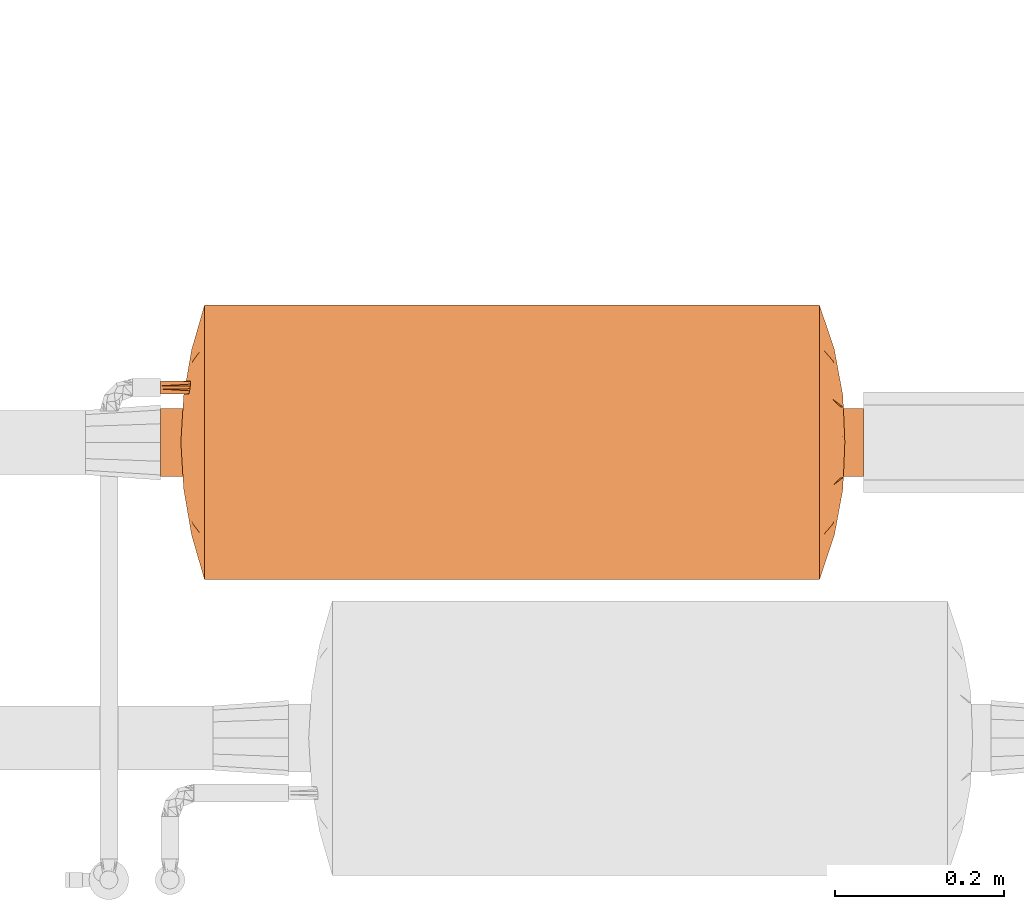
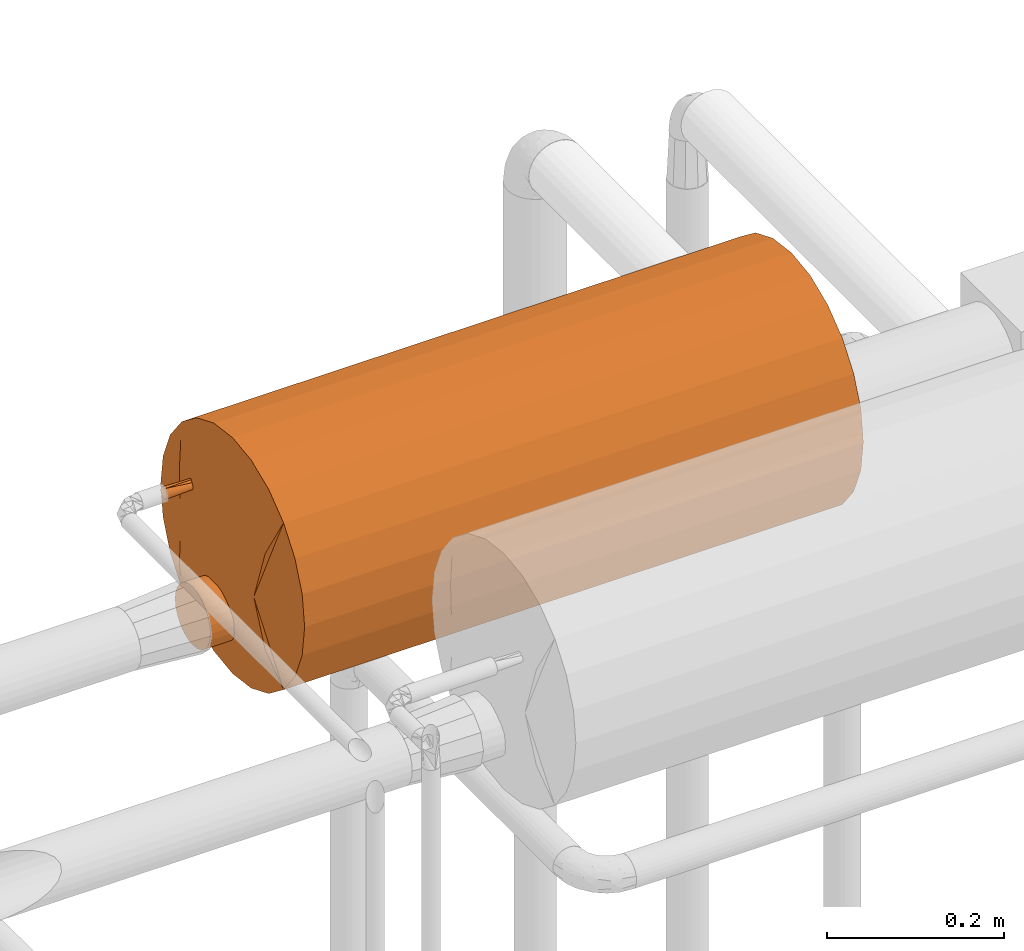
# One storey, part 827 of 827: 1 proxy.
"""IFC2X3 building model written with IfcOpenShell, lengths in millimetres."""

from ifc_helpers import new_model, entity, si_unit, converted_unit, derived_unit, direction, frame, origin, place, context, subcontext, project, spatial, faceted_brep, source, transform, mapped, material, material_list, type_object, type_shapes, element, save


model = new_model("IFC2X3")

# Units and contexts
model_context = context("Model", 3, precision=0.01, world=origin(), true_north=direction((6.12303176911189e-17, 1.0)))
body_context = subcontext(model_context, "Body", "Model", "MODEL_VIEW")
ifc_project = project(units=[si_unit("LENGTHUNIT", "METRE", prefix="MILLI"), si_unit("AREAUNIT", "SQUARE_METRE"), si_unit("VOLUMEUNIT", "CUBIC_METRE"), converted_unit("PLANEANGLEUNIT", "DEGREE", entity("IfcRatioMeasure", 0.0174532925199433), si_unit("PLANEANGLEUNIT", "RADIAN"), dimensions=[0, 0, 0, 0, 0, 0, 0]), si_unit("MASSUNIT", "GRAM", prefix="KILO"), derived_unit("MASSDENSITYUNIT", [(si_unit("MASSUNIT", "GRAM", prefix="KILO"), 1), (si_unit("LENGTHUNIT", "METRE"), -3)]), derived_unit("MOMENTOFINERTIAUNIT", [(si_unit("LENGTHUNIT", "METRE"), 4)]), si_unit("TIMEUNIT", "SECOND"), si_unit("FREQUENCYUNIT", "HERTZ"), si_unit("THERMODYNAMICTEMPERATUREUNIT", "DEGREE_CELSIUS"), derived_unit("THERMALTRANSMITTANCEUNIT", [(si_unit("MASSUNIT", "GRAM", prefix="KILO"), 1), (si_unit("THERMODYNAMICTEMPERATUREUNIT", "KELVIN"), -1), (si_unit("TIMEUNIT", "SECOND"), -3)]), derived_unit("VOLUMETRICFLOWRATEUNIT", [(si_unit("LENGTHUNIT", "METRE"), 3), (si_unit("TIMEUNIT", "SECOND"), -1)]), derived_unit("MASSFLOWRATEUNIT", [(si_unit("MASSUNIT", "GRAM", prefix="KILO"), 1), (si_unit("TIMEUNIT", "SECOND"), -1)]), derived_unit("ROTATIONALFREQUENCYUNIT", [(si_unit("TIMEUNIT", "SECOND"), -1)]), si_unit("ELECTRICCURRENTUNIT", "AMPERE"), si_unit("ELECTRICVOLTAGEUNIT", "VOLT"), si_unit("POWERUNIT", "WATT"), si_unit("FORCEUNIT", "NEWTON", prefix="KILO"), si_unit("ILLUMINANCEUNIT", "LUX"), si_unit("LUMINOUSFLUXUNIT", "LUMEN"), si_unit("LUMINOUSINTENSITYUNIT", "CANDELA"), derived_unit("USERDEFINED", [(si_unit("MASSUNIT", "GRAM", prefix="KILO"), -1), (si_unit("LENGTHUNIT", "METRE"), -2), (si_unit("TIMEUNIT", "SECOND"), 3), (si_unit("LUMINOUSFLUXUNIT", "LUMEN"), 1)]), derived_unit("LINEARVELOCITYUNIT", [(si_unit("LENGTHUNIT", "METRE"), 1), (si_unit("TIMEUNIT", "SECOND"), -1)]), si_unit("PRESSUREUNIT", "PASCAL"), derived_unit("USERDEFINED", [(si_unit("LENGTHUNIT", "METRE"), -2), (si_unit("MASSUNIT", "GRAM", prefix="KILO"), 1), (si_unit("TIMEUNIT", "SECOND"), -2)]), derived_unit("LINEARFORCEUNIT", [(si_unit("MASSUNIT", "GRAM", prefix="KILO"), 1), (si_unit("LENGTHUNIT", "METRE"), 1), (si_unit("TIMEUNIT", "SECOND"), -2), (si_unit("LENGTHUNIT", "METRE"), -1)]), derived_unit("PLANARFORCEUNIT", [(si_unit("MASSUNIT", "GRAM", prefix="KILO"), 1), (si_unit("LENGTHUNIT", "METRE"), 1), (si_unit("TIMEUNIT", "SECOND"), -2), (si_unit("LENGTHUNIT", "METRE"), -2)])], contexts=[model_context])

# Site, building, storey
site_placement = place(None, origin())
site = spatial("IfcSite", under=ifc_project, at=site_placement, CompositionType="ELEMENT")
building_placement = place(site_placement, origin())
building = spatial("IfcBuilding", under=site, at=building_placement, CompositionType="ELEMENT")
storey_placement = place(building_placement, frame((0.0, 0.0, 28200.0)))
storey = spatial("IfcBuildingStorey", under=building, at=storey_placement, Name="08", CompositionType="ELEMENT", Elevation=28200.0)

# Proxy
ifc_material_1 = material()
ifc_material_2 = material()
ifc_material_3 = material()
ifc_material_list = material_list([ifc_material_1, ifc_material_2, ifc_material_3])
building_element_proxy_type = type_object("IfcBuildingElementProxyType", Name=":Dy80", PredefinedType="NOTDEFINED", material=ifc_material_1)
shared_shape = source(origin(), body_context, "Body", "Brep", [
    faceted_brep([(66.94, 416.0, 57.76), (65.0, 416.0, 57.5), (63.06, 416.0, 57.76), (61.25, 416.0, 58.5), (59.7, 416.0, 59.7), (58.5, 416.0, 61.25), (57.76, 416.0, 63.06), (57.5, 416.0, 65.0), (57.76, 416.0, 66.94), (58.5, 416.0, 68.75), (59.7, 416.0, 70.3), (61.25, 416.0, 71.5), (63.06, 416.0, 72.24), (65.0, 416.0, 72.5), (66.94, 416.0, 72.24), (68.75, 416.0, 71.5), (70.3, 416.0, 70.3), (71.5, 416.0, 68.75), (72.24, 416.0, 66.94), (72.5, 416.0, 65.0), (72.24, 416.0, 63.06), (71.5, 416.0, 61.25), (70.3, 416.0, 59.7), (68.75, 416.0, 58.5), (68.75, 0.0, 71.5), (66.94, 0.0, 72.24), (65.0, 0.0, 72.5), (63.06, 0.0, 72.24), (61.25, 0.0, 71.5), (59.7, 0.0, 70.3), (58.5, 0.0, 68.75), (57.76, 0.0, 66.94), (57.5, 0.0, 65.0), (57.76, 0.0, 63.06), (58.5, 0.0, 61.25), (59.7, 0.0, 59.7), (61.25, 0.0, 58.5), (63.06, 0.0, 57.76), (65.0, 0.0, 57.5), (66.94, 0.0, 57.76), (68.75, 0.0, 58.5), (70.3, 0.0, 59.7), (71.5, 0.0, 61.25), (72.24, 0.0, 63.06), (72.5, 0.0, 65.0), (72.24, 0.0, 66.94), (71.5, 0.0, 68.75), (70.3, 0.0, 70.3), (72.5, 320.38, 65.0), (65.49, 181.32, 57.52), (72.5, 224.75, 65.0), (72.5, 208.0, 65.0), (72.5, 95.62, 65.0), (65.0, 272.56, 57.5), (57.5, 208.0, 65.0), (57.5, 224.75, 65.0), (57.5, 320.38, 65.0), (65.0, 84.55, 57.5), (57.5, 95.62, 65.0), (65.0, 84.55, 72.5), (65.0, 272.56, 72.5), (64.51, 181.32, 72.48)], [[[0, 1, 2, 3, 4, 5, 6, 7, 8, 9, 10, 11, 12, 13, 14, 15, 16, 17, 18, 19, 20, 21, 22, 23]], [[24, 25, 26, 27, 28, 29, 30, 31, 32, 33, 34, 35, 36, 37, 38, 39, 40, 41, 42, 43, 44, 45, 46, 47]], [[23, 22, 48]], [[49, 50, 51, 52]], [[53, 54, 55, 56]], [[37, 36, 57]], [[48, 22, 21]], [[37, 57, 38]], [[1, 53, 2]], [[56, 5, 4]], [[35, 34, 58]], [[57, 40, 39]], [[49, 57, 58]], [[33, 32, 58]], [[56, 7, 6]], [[54, 49, 58]], [[56, 6, 5]], [[53, 49, 54]], [[20, 19, 48]], [[52, 44, 43]], [[35, 57, 36]], [[40, 57, 41]], [[48, 50, 53]], [[33, 58, 34]], [[52, 42, 41]], [[52, 57, 49]], [[43, 42, 52]], [[57, 35, 58]], [[49, 53, 50]], [[20, 48, 21]], [[38, 57, 39]], [[0, 53, 1]], [[4, 3, 56]], [[0, 48, 53]], [[48, 0, 23]], [[2, 53, 56]], [[56, 3, 2]], [[57, 52, 41]], [[56, 11, 10]], [[25, 24, 59]], [[56, 10, 9]], [[25, 59, 26]], [[13, 60, 14]], [[47, 46, 52]], [[59, 28, 27]], [[61, 55, 54, 58]], [[56, 55, 60]], [[61, 59, 52]], [[45, 44, 52]], [[48, 19, 18]], [[17, 16, 48]], [[18, 17, 48]], [[8, 7, 56]], [[58, 32, 31]], [[61, 51, 60]], [[51, 61, 52]], [[29, 28, 59]], [[47, 59, 24]], [[58, 30, 29]], [[60, 51, 50, 48]], [[58, 59, 61]], [[31, 30, 58]], [[47, 52, 59]], [[55, 61, 60]], [[8, 56, 9]], [[12, 60, 13]], [[26, 59, 27]], [[16, 15, 48]], [[12, 56, 60]], [[56, 12, 11]], [[60, 48, 14]], [[48, 15, 14]], [[45, 52, 46]], [[59, 58, 29]]]),
    faceted_brep([(28.17, 416.0, -93.28), (19.88, 416.0, -99.64), (10.24, 416.0, -103.64), (-0.12, 416.0, -105.0), (-10.47, 416.0, -103.64), (-20.12, 416.0, -99.64), (-28.4, 416.0, -93.28), (-34.76, 416.0, -85.0), (-38.75, 416.0, -75.35), (-40.12, 416.0, -65.0), (-38.75, 416.0, -54.65), (-34.76, 416.0, -45.0), (-28.4, 416.0, -36.72), (-20.12, 416.0, -30.36), (-10.47, 416.0, -26.36), (-0.12, 416.0, -25.0), (10.24, 416.0, -26.36), (19.88, 416.0, -30.36), (28.17, 416.0, -36.72), (34.52, 416.0, -45.0), (38.52, 416.0, -54.65), (39.88, 416.0, -65.0), (38.52, 416.0, -75.35), (34.52, 416.0, -85.0), (19.88, -416.0, -30.36), (10.24, -416.0, -26.36), (-0.12, -416.0, -25.0), (-10.47, -416.0, -26.36), (-20.12, -416.0, -30.36), (-28.4, -416.0, -36.72), (-34.76, -416.0, -45.0), (-38.75, -416.0, -54.65), (-40.12, -416.0, -65.0), (-38.75, -416.0, -75.35), (-34.76, -416.0, -85.0), (-28.4, -416.0, -93.28), (-20.12, -416.0, -99.64), (-10.47, -416.0, -103.64), (-0.12, -416.0, -105.0), (10.24, -416.0, -103.64), (19.88, -416.0, -99.64), (28.17, -416.0, -93.28), (34.52, -416.0, -85.0), (38.52, -416.0, -75.35), (39.88, -416.0, -65.0), (38.52, -416.0, -54.65), (34.52, -416.0, -45.0), (28.17, -416.0, -36.72), (-37.07, 0.0, -80.31), (-5.34, 184.0, -104.66), (-15.42, 0.0, -101.96), (-31.85, -103.67, -89.35), (-31.85, 184.0, -89.35), (-24.47, 103.67, -96.73), (-24.47, -184.0, -96.73), (31.62, -184.0, -89.35), (24.23, -103.67, -96.73), (31.62, 103.67, -89.35), (24.23, 184.0, -96.73), (-5.34, -103.67, -104.66), (-39.35, -138.45, -72.8), (-39.41, 146.88, -72.49), (-40.12, 0.0, -65.0), (5.1, 103.67, -104.66), (5.1, -184.0, -104.66), (15.19, 0.0, -101.96), (36.84, 0.0, -80.31), (39.17, -146.88, -72.49), (39.88, 0.0, -65.0), (39.11, 138.45, -72.8), (39.88, 25.67, -65.0), (24.23, 184.0, -33.27), (36.84, -184.0, -49.69), (31.62, 0.0, -40.65), (24.23, -103.67, -33.27), (15.19, 0.0, -28.04), (-31.85, -184.0, -40.65), (-24.47, -103.67, -33.27), (-31.85, 103.67, -40.65), (-24.47, 184.0, -33.27), (5.1, -103.67, -25.34), (39.15, 107.63, -57.39), (39.29, -153.03, -58.11), (36.84, 103.67, -49.69), (5.1, 184.0, -25.34), (-15.42, 0.0, -28.04), (-5.34, -184.0, -25.34), (-5.34, 103.67, -25.34), (-37.07, 0.0, -49.69), (-39.41, -146.88, -57.51), (-39.35, 138.45, -57.2)], [[[0, 1, 2, 3, 4, 5, 6, 7, 8, 9, 10, 11, 12, 13, 14, 15, 16, 17, 18, 19, 20, 21, 22, 23]], [[24, 25, 26, 27, 28, 29, 30, 31, 32, 33, 34, 35, 36, 37, 38, 39, 40, 41, 42, 43, 44, 45, 46, 47]], [[34, 33, 48]], [[4, 49, 50]], [[51, 52, 53, 54]], [[48, 51, 34]], [[37, 36, 50]], [[55, 41, 56]], [[0, 57, 58]], [[53, 50, 54]], [[7, 52, 48]], [[37, 50, 59]], [[60, 48, 33]], [[61, 62, 9]], [[32, 60, 33]], [[51, 35, 34]], [[6, 5, 53]], [[48, 8, 7]], [[3, 2, 63]], [[52, 51, 48]], [[50, 53, 5]], [[56, 41, 40]], [[50, 5, 4]], [[59, 38, 37]], [[49, 59, 50]], [[59, 49, 63, 64]], [[40, 39, 65]], [[64, 38, 59]], [[3, 63, 49]], [[65, 56, 40]], [[43, 42, 66]], [[55, 42, 41]], [[54, 35, 51]], [[57, 66, 55]], [[0, 58, 1]], [[67, 68, 44]], [[63, 2, 65]], [[65, 2, 1]], [[54, 36, 35]], [[0, 23, 57]], [[61, 60, 62]], [[58, 56, 65]], [[3, 49, 4]], [[57, 23, 66]], [[22, 66, 23]], [[64, 39, 38]], [[22, 69, 66]], [[6, 52, 7]], [[6, 53, 52]], [[64, 63, 65]], [[67, 69, 68]], [[22, 21, 69]], [[36, 54, 50]], [[1, 58, 65]], [[56, 58, 57, 55]], [[39, 64, 65]], [[42, 55, 66]], [[8, 48, 61]], [[62, 60, 32]], [[60, 61, 48]], [[8, 61, 9]], [[43, 66, 67]], [[69, 21, 70, 68]], [[69, 67, 66]], [[43, 67, 44]], [[71, 18, 17]], [[46, 72, 73]], [[74, 71, 75]], [[46, 73, 47]], [[25, 24, 75]], [[76, 29, 77]], [[12, 78, 79]], [[74, 47, 73]], [[18, 71, 73]], [[25, 75, 80]], [[81, 70, 21]], [[82, 72, 45]], [[77, 29, 28]], [[74, 24, 47]], [[20, 19, 83]], [[83, 19, 73]], [[72, 83, 73]], [[73, 19, 18]], [[74, 73, 71]], [[80, 26, 25]], [[75, 17, 16]], [[45, 44, 82]], [[84, 80, 75]], [[82, 81, 83]], [[28, 27, 85]], [[86, 26, 80]], [[15, 87, 84]], [[85, 77, 28]], [[31, 30, 88]], [[76, 30, 29]], [[15, 84, 16]], [[78, 88, 76]], [[12, 79, 13]], [[89, 62, 32]], [[87, 14, 85]], [[85, 14, 13]], [[12, 11, 78]], [[10, 9, 90]], [[71, 17, 75]], [[79, 77, 85]], [[45, 72, 46]], [[78, 11, 88]], [[10, 88, 11]], [[70, 81, 82]], [[10, 90, 88]], [[74, 75, 24]], [[86, 27, 26]], [[86, 87, 85]], [[89, 90, 62]], [[15, 14, 87]], [[72, 82, 83]], [[82, 44, 68, 70]], [[81, 20, 83]], [[20, 81, 21]], [[16, 84, 75]], [[80, 84, 87, 86]], [[13, 79, 85]], [[77, 79, 78]], [[27, 86, 85]], [[30, 76, 88]], [[78, 76, 77]], [[31, 88, 89]], [[62, 90, 9]], [[90, 89, 88]], [[31, 89, 32]]]),
    faceted_brep([(-159.69, 364.0, -21.32), (-161.1, 364.0, -10.66), (-162.5, 364.0, 0.0), (-155.82, 365.93, 0.0), (-149.15, 367.86, 0.0), (-135.8, 371.72, 0.0), (-156.96, 364.0, -42.06), (41.32, 389.51, 0.0), (67.08, 379.71, -84.46), (47.38, 383.12, -78.27), (-144.79, 364.0, -71.45), (-109.48, 379.34, 0.0), (-140.73, 364.0, -81.25), (85.05, 378.12, -76.87), (98.08, 364.0, -127.82), (81.25, 364.0, -140.73), (55.09, 388.69, 0.0), (68.69, 386.35, 0.0), (-95.89, 381.68, 0.0), (-82.29, 384.01, 0.0), (-114.9, 364.0, -114.9), (149.15, 367.86, 0.0), (155.82, 365.93, 0.0), (162.5, 364.0, 0.0), (161.1, 364.0, -10.66), (159.69, 364.0, -21.32), (156.96, 364.0, -42.06), (135.8, 371.72, 0.0), (-127.82, 364.0, -98.08), (-13.77, 391.14, 0.0), (0.0, 391.96, 0.0), (0.64, 388.56, -56.2), (95.89, 381.68, 0.0), (114.9, 364.0, -114.9), (82.29, 384.01, 0.0), (0.35, 379.22, -109.99), (-15.85, 384.77, -80.88), (-67.08, 379.71, -84.46), (-85.05, 378.12, -76.87), (-55.09, 388.69, 0.0), (-98.08, 364.0, -127.82), (-81.25, 364.0, -140.73), (-122.64, 375.53, 0.0), (-116.06, 377.43, 0.0), (96.75, 377.52, -65.95), (109.48, 379.34, 0.0), (127.82, 364.0, -98.08), (27.55, 390.33, 0.0), (140.73, 364.0, -81.25), (116.06, 377.43, 0.0), (148.85, 364.0, -61.65), (-148.85, 364.0, -61.65), (122.64, 375.53, 0.0), (32.54, 386.74, -62.05), (29.41, 377.03, -115.39), (-96.75, 377.52, -65.95), (-68.69, 386.35, 0.0), (16.83, 384.52, -82.16), (61.65, 364.0, -148.85), (-61.65, 364.0, -148.85), (13.77, 391.14, 0.0), (-28.0, 377.32, -114.56), (-41.32, 389.51, 0.0), (-47.38, 383.12, -78.27), (-32.15, 386.68, -62.66), (-27.55, 390.33, 0.0), (-42.06, 364.0, -156.96), (42.06, 364.0, -156.96), (21.03, 364.0, -159.73), (0.0, 364.0, -162.5), (-21.03, 364.0, -159.73), (159.69, 364.0, 21.32), (161.1, 364.0, 10.66), (156.96, 364.0, 42.06), (-67.08, 379.71, 84.46), (-47.38, 383.12, 78.27), (144.79, 364.0, 71.45), (140.73, 364.0, 81.25), (-85.05, 378.12, 76.87), (-98.08, 364.0, 127.82), (-81.25, 364.0, 140.73), (114.9, 364.0, 114.9), (-159.69, 364.0, 21.32), (-156.96, 364.0, 42.06), (-161.1, 364.0, 10.66), (127.82, 364.0, 98.08), (-0.64, 388.56, 56.2), (-114.9, 364.0, 114.9), (-0.35, 379.22, 109.99), (15.85, 384.77, 80.88), (67.08, 379.71, 84.46), (85.05, 378.12, 76.87), (98.08, 364.0, 127.82), (81.25, 364.0, 140.73), (-96.75, 377.52, 65.95), (-127.82, 364.0, 98.08), (-140.73, 364.0, 81.25), (-148.85, 364.0, 61.65), (148.85, 364.0, 61.65), (-32.54, 386.74, 62.05), (-29.41, 377.03, 115.39), (96.75, 377.52, 65.95), (-16.83, 384.52, 82.16), (-61.65, 364.0, 148.85), (61.65, 364.0, 148.85), (28.0, 377.32, 114.56), (47.38, 383.12, 78.27), (32.15, 386.68, 62.66), (42.06, 364.0, 156.96), (-42.06, 364.0, 156.96), (-21.03, 364.0, 159.73), (0.0, 364.0, 162.5), (21.03, 364.0, 159.73), (0.0, 364.0, 0.0)], [[[0, 1, 2, 3, 4, 5, 6]], [[7, 8, 9]], [[10, 11, 12]], [[13, 14, 15]], [[13, 16, 17]], [[18, 19, 20]], [[21, 22, 23, 24, 25, 26, 27]], [[20, 28, 18]], [[29, 30, 31]], [[32, 33, 34]], [[35, 36, 31]], [[37, 38, 39]], [[40, 38, 41]], [[10, 42, 43, 11]], [[13, 44, 14]], [[32, 45, 46]], [[9, 47, 7]], [[11, 28, 12]], [[13, 8, 16]], [[48, 49, 50]], [[18, 28, 11]], [[34, 33, 44]], [[44, 13, 17]], [[48, 46, 45]], [[26, 50, 27]], [[45, 49, 48]], [[10, 51, 42]], [[5, 51, 6]], [[52, 27, 50, 49]], [[42, 51, 5]], [[53, 9, 54]], [[46, 33, 32]], [[38, 55, 56]], [[53, 54, 57]], [[8, 13, 15]], [[8, 58, 9]], [[7, 16, 8]], [[53, 47, 9]], [[59, 41, 37]], [[57, 60, 53]], [[35, 61, 36]], [[37, 62, 63]], [[61, 64, 36]], [[63, 65, 64]], [[55, 38, 40]], [[20, 55, 40]], [[41, 38, 37]], [[38, 56, 39]], [[66, 59, 63]], [[59, 37, 63]], [[65, 63, 62]], [[37, 39, 62]], [[61, 66, 63]], [[67, 9, 58]], [[8, 15, 58]], [[14, 44, 33]], [[44, 17, 34]], [[55, 19, 56]], [[19, 55, 20]], [[57, 68, 35]], [[60, 31, 30]], [[54, 68, 57]], [[60, 47, 53]], [[54, 67, 68]], [[67, 54, 9]], [[69, 35, 68]], [[57, 35, 31]], [[57, 31, 60]], [[36, 29, 31]], [[61, 35, 70]], [[65, 29, 64]], [[70, 35, 69]], [[36, 64, 29]], [[64, 61, 63]], [[61, 70, 66]], [[71, 72, 23, 22, 21, 27, 73]], [[62, 74, 75]], [[76, 45, 77]], [[78, 79, 80]], [[78, 39, 56]], [[32, 34, 81]], [[82, 83, 5, 4, 3, 2, 84]], [[81, 85, 32]], [[60, 30, 86]], [[18, 87, 19]], [[88, 89, 86]], [[90, 91, 16]], [[92, 91, 93]], [[76, 52, 49, 45]], [[78, 94, 79]], [[18, 11, 95]], [[75, 65, 62]], [[45, 85, 77]], [[78, 74, 39]], [[96, 43, 97]], [[32, 85, 45]], [[19, 87, 94]], [[94, 78, 56]], [[96, 95, 11]], [[83, 97, 5]], [[11, 43, 96]], [[76, 98, 52]], [[27, 98, 73]], [[42, 5, 97, 43]], [[52, 98, 27]], [[99, 75, 100]], [[95, 87, 18]], [[91, 101, 17]], [[99, 100, 102]], [[74, 78, 80]], [[74, 103, 75]], [[62, 39, 74]], [[99, 65, 75]], [[104, 93, 90]], [[102, 29, 99]], [[88, 105, 89]], [[90, 7, 106]], [[102, 88, 86]], [[106, 47, 107]], [[101, 91, 92]], [[81, 101, 92]], [[93, 91, 90]], [[91, 17, 16]], [[108, 104, 106]], [[104, 90, 106]], [[47, 106, 7]], [[90, 16, 7]], [[105, 108, 106]], [[109, 75, 103]], [[74, 80, 103]], [[79, 94, 87]], [[94, 56, 19]], [[101, 34, 17]], [[34, 101, 81]], [[102, 110, 88]], [[29, 86, 30]], [[100, 110, 102]], [[29, 65, 99]], [[100, 109, 110]], [[109, 100, 75]], [[105, 107, 89]], [[111, 88, 110]], [[102, 86, 29]], [[89, 60, 86]], [[105, 88, 112]], [[47, 60, 107]], [[112, 88, 111]], [[89, 107, 60]], [[107, 105, 106]], [[105, 112, 108]], [[113, 26, 25]], [[113, 25, 24]], [[113, 24, 23]], [[113, 23, 72]], [[113, 50, 26]], [[113, 48, 50]], [[113, 46, 48]], [[113, 33, 46]], [[113, 14, 33]], [[113, 15, 14]], [[113, 58, 15]], [[113, 67, 58]], [[113, 68, 67]], [[113, 69, 68]], [[113, 70, 69]], [[113, 66, 70]], [[113, 59, 66]], [[113, 41, 59]], [[113, 40, 41]], [[113, 20, 40]], [[113, 28, 20]], [[113, 12, 28]], [[113, 10, 12]], [[113, 51, 10]], [[113, 6, 51]], [[113, 0, 6]], [[113, 1, 0]], [[113, 2, 1]], [[113, 72, 71]], [[113, 71, 73]], [[113, 73, 98]], [[113, 98, 76]], [[113, 76, 77]], [[113, 77, 85]], [[113, 85, 81]], [[113, 81, 92]], [[113, 92, 93]], [[113, 93, 104]], [[113, 104, 108]], [[113, 108, 112]], [[113, 112, 111]], [[113, 111, 110]], [[113, 84, 2]], [[113, 82, 84]], [[113, 83, 82]], [[113, 97, 83]], [[113, 96, 97]], [[113, 95, 96]], [[113, 87, 95]], [[113, 79, 87]], [[113, 80, 79]], [[113, 103, 80]], [[113, 109, 103]], [[113, 110, 109]]]),
    faceted_brep([(-96.96, -379.53, -66.85), (-85.06, -380.44, -76.61), (-69.03, -389.19, 0.0), (-160.28, -364.0, -16.87), (-159.45, -364.0, -23.17), (-158.62, -364.0, -29.46), (-156.96, -364.0, -42.06), (-133.54, -373.72, 0.0), (-141.41, -371.08, 0.0), (-146.69, -369.31, 0.0), (-151.96, -367.54, 0.0), (-162.5, -364.0, 0.0), (160.28, -364.0, -16.87), (162.5, -364.0, 0.0), (151.96, -367.54, 0.0), (146.69, -369.31, 0.0), (141.41, -371.08, 0.0), (133.54, -373.72, 0.0), (156.96, -364.0, -42.06), (158.62, -364.0, -29.46), (159.45, -364.0, -23.17), (-36.26, -378.67, -115.22), (-51.54, -378.96, -108.11), (-42.06, -364.0, -156.96), (-41.55, -392.28, 0.0), (-55.4, -391.71, 0.0), (-66.57, -382.24, -84.52), (-109.93, -381.64, 0.0), (-148.85, -364.0, -61.65), (-140.73, -364.0, -81.25), (-127.82, -364.0, -98.08), (148.85, -364.0, -61.65), (-125.67, -376.36, 0.0), (-82.67, -386.68, 0.0), (-114.9, -364.0, -114.9), (140.73, -364.0, -81.25), (109.93, -381.64, 0.0), (66.57, -382.24, -84.52), (41.55, -392.28, 0.0), (51.54, -378.96, -108.11), (127.82, -364.0, -98.08), (96.3, -384.16, 0.0), (114.9, -364.0, -114.9), (125.67, -376.36, 0.0), (85.06, -380.44, -76.61), (81.25, -364.0, -140.73), (96.96, -379.53, -66.85), (69.03, -389.19, 0.0), (98.08, -364.0, -127.82), (-96.3, -384.16, 0.0), (82.67, -386.68, 0.0), (13.85, -393.43, 0.0), (0.0, -394.0, 0.0), (7.51, -388.27, -79.01), (-98.08, -364.0, -127.82), (-81.25, -364.0, -140.73), (-61.65, -364.0, -148.85), (-7.04, -391.55, -56.37), (-13.85, -393.43, 0.0), (-22.95, -385.16, -92.34), (-42.17, -388.61, -64.85), (-27.7, -392.85, 0.0), (55.4, -391.71, 0.0), (42.17, -388.61, -64.85), (36.26, -378.67, -115.22), (61.65, -364.0, -148.85), (-21.03, -364.0, -159.73), (42.06, -364.0, -156.96), (22.95, -385.16, -92.34), (21.03, -364.0, -159.73), (-4.64, -381.32, -111.09), (0.0, -364.0, -162.5), (28.55, -391.9, -45.49), (27.7, -392.85, 0.0), (96.96, -379.53, 66.85), (85.06, -380.44, 76.61), (160.28, -364.0, 16.87), (159.45, -364.0, 23.17), (158.62, -364.0, 29.46), (156.96, -364.0, 42.06), (148.85, -364.0, 61.65), (36.26, -378.67, 115.22), (51.54, -378.96, 108.11), (42.06, -364.0, 156.96), (66.57, -382.24, 84.52), (-156.96, -364.0, 42.06), (-158.62, -364.0, 29.46), (-159.45, -364.0, 23.17), (-160.28, -364.0, 16.87), (140.73, -364.0, 81.25), (127.82, -364.0, 98.08), (114.9, -364.0, 114.9), (-85.06, -380.44, 76.61), (-96.96, -379.53, 66.85), (-140.73, -364.0, 81.25), (-148.85, -364.0, 61.65), (-66.57, -382.24, 84.52), (-51.54, -378.96, 108.11), (-127.82, -364.0, 98.08), (-114.9, -364.0, 114.9), (-81.25, -364.0, 140.73), (-98.08, -364.0, 127.82), (-7.51, -388.27, 79.01), (98.08, -364.0, 127.82), (81.25, -364.0, 140.73), (61.65, -364.0, 148.85), (7.04, -391.55, 56.37), (22.95, -385.16, 92.34), (42.17, -388.61, 64.85), (-42.17, -388.61, 64.85), (-36.26, -378.67, 115.22), (-61.65, -364.0, 148.85), (21.03, -364.0, 159.73), (-42.06, -364.0, 156.96), (-22.95, -385.16, 92.34), (-21.03, -364.0, 159.73), (4.64, -381.32, 111.09), (0.0, -364.0, 162.5), (-28.55, -391.9, 45.49), (0.0, -364.0, 0.0)], [[[0, 1, 2]], [[3, 4, 5, 6, 7, 8, 9, 10, 11]], [[12, 13, 14, 15, 16, 17, 18, 19, 20]], [[21, 22, 23]], [[24, 25, 26]], [[25, 1, 26]], [[27, 28, 29]], [[29, 30, 27]], [[6, 28, 7]], [[18, 17, 31]], [[28, 27, 32, 7]], [[33, 34, 0]], [[35, 31, 36]], [[37, 38, 39]], [[40, 41, 42]], [[31, 17, 43, 36]], [[44, 37, 45]], [[44, 46, 47]], [[48, 44, 45]], [[49, 27, 30]], [[41, 50, 42]], [[51, 52, 53]], [[30, 34, 49]], [[49, 34, 33]], [[41, 40, 36]], [[36, 40, 35]], [[1, 0, 54]], [[1, 54, 55]], [[1, 25, 2]], [[56, 23, 22]], [[57, 58, 59]], [[26, 1, 55]], [[26, 56, 22]], [[46, 44, 48]], [[60, 61, 24]], [[42, 46, 48]], [[44, 62, 37]], [[44, 47, 62]], [[63, 64, 39]], [[65, 45, 37]], [[39, 65, 37]], [[26, 22, 24]], [[37, 62, 38]], [[26, 55, 56]], [[21, 59, 60]], [[59, 61, 60]], [[21, 66, 59]], [[67, 39, 64]], [[67, 65, 39]], [[38, 63, 39]], [[68, 69, 64]], [[57, 59, 70]], [[54, 0, 34]], [[0, 2, 33]], [[46, 50, 47]], [[50, 46, 42]], [[22, 21, 60]], [[22, 60, 24]], [[66, 70, 59]], [[21, 23, 66]], [[58, 61, 59]], [[69, 70, 71]], [[63, 72, 68]], [[69, 67, 64]], [[64, 63, 68]], [[73, 63, 38]], [[51, 53, 72]], [[52, 58, 57]], [[70, 69, 68]], [[57, 70, 53]], [[51, 72, 73]], [[71, 70, 66]], [[52, 57, 53]], [[53, 70, 68]], [[73, 72, 63]], [[68, 72, 53]], [[74, 75, 47]], [[76, 77, 78, 79, 17, 16, 15, 14, 13]], [[80, 36, 43, 17]], [[81, 82, 83]], [[38, 62, 84]], [[62, 75, 84]], [[8, 7, 85, 86, 87, 88, 11, 10, 9]], [[36, 80, 89]], [[89, 90, 36]], [[79, 80, 17]], [[41, 36, 90]], [[50, 91, 74]], [[92, 93, 2]], [[94, 95, 27]], [[96, 24, 97]], [[98, 49, 99]], [[92, 96, 100]], [[49, 33, 99]], [[101, 92, 100]], [[32, 27, 95, 7]], [[58, 52, 102]], [[85, 7, 95]], [[90, 91, 41]], [[41, 91, 50]], [[49, 98, 27]], [[27, 98, 94]], [[75, 74, 103]], [[75, 103, 104]], [[75, 62, 47]], [[105, 83, 82]], [[106, 51, 107]], [[84, 75, 104]], [[84, 105, 82]], [[93, 92, 101]], [[108, 73, 38]], [[99, 93, 101]], [[92, 25, 96]], [[92, 2, 25]], [[109, 110, 97]], [[111, 100, 96]], [[97, 111, 96]], [[84, 82, 38]], [[96, 25, 24]], [[84, 104, 105]], [[81, 107, 108]], [[107, 73, 108]], [[81, 112, 107]], [[113, 97, 110]], [[113, 111, 97]], [[24, 109, 97]], [[114, 115, 110]], [[106, 107, 116]], [[103, 74, 91]], [[74, 47, 50]], [[93, 33, 2]], [[33, 93, 99]], [[82, 81, 108]], [[82, 108, 38]], [[112, 116, 107]], [[81, 83, 112]], [[51, 73, 107]], [[115, 116, 117]], [[109, 118, 114]], [[115, 113, 110]], [[110, 109, 114]], [[61, 109, 24]], [[58, 102, 118]], [[52, 51, 106]], [[116, 115, 114]], [[106, 116, 102]], [[58, 118, 61]], [[117, 116, 112]], [[52, 106, 102]], [[102, 116, 114]], [[61, 118, 109]], [[114, 118, 102]], [[119, 13, 12]], [[119, 12, 20]], [[119, 20, 19]], [[119, 19, 18]], [[119, 18, 31]], [[119, 31, 35]], [[119, 35, 40]], [[119, 40, 42]], [[119, 42, 48]], [[119, 48, 45]], [[119, 45, 65]], [[119, 65, 67]], [[119, 67, 69]], [[119, 69, 71]], [[119, 71, 66]], [[119, 66, 23]], [[119, 23, 56]], [[119, 56, 55]], [[119, 55, 54]], [[119, 54, 34]], [[119, 34, 30]], [[119, 30, 29]], [[119, 29, 28]], [[119, 28, 6]], [[119, 6, 5]], [[119, 5, 4]], [[119, 4, 3]], [[119, 3, 11]], [[119, 11, 88]], [[119, 76, 13]], [[119, 77, 76]], [[119, 78, 77]], [[119, 79, 78]], [[119, 80, 79]], [[119, 89, 80]], [[119, 90, 89]], [[119, 91, 90]], [[119, 103, 91]], [[119, 104, 103]], [[119, 105, 104]], [[119, 83, 105]], [[119, 112, 83]], [[119, 117, 112]], [[119, 88, 87]], [[119, 87, 86]], [[119, 86, 85]], [[119, 85, 95]], [[119, 95, 94]], [[119, 94, 98]], [[119, 98, 99]], [[119, 99, 101]], [[119, 101, 100]], [[119, 100, 111]], [[119, 111, 113]], [[119, 113, 115]], [[119, 115, 117]]]),
    faceted_brep([(42.06, 364.0, -156.96), (0.0, 364.0, -162.5), (-42.06, 364.0, -156.96), (-81.25, 364.0, -140.73), (-114.9, 364.0, -114.9), (-140.73, 364.0, -81.25), (-156.96, 364.0, -42.06), (-162.5, 364.0, 0.0), (-156.96, 364.0, 42.06), (-140.73, 364.0, 81.25), (-114.9, 364.0, 114.9), (-81.25, 364.0, 140.73), (-42.06, 364.0, 156.96), (0.0, 364.0, 162.5), (42.06, 364.0, 156.96), (81.25, 364.0, 140.73), (114.9, 364.0, 114.9), (140.73, 364.0, 81.25), (156.96, 364.0, 42.06), (162.5, 364.0, 0.0), (156.96, 364.0, -42.06), (140.73, 364.0, -81.25), (114.9, 364.0, -114.9), (81.25, 364.0, -140.73), (42.06, -364.0, 156.96), (0.0, -364.0, 162.5), (-42.06, -364.0, 156.96), (-81.25, -364.0, 140.73), (-114.9, -364.0, 114.9), (-140.73, -364.0, 81.25), (-156.96, -364.0, 42.06), (-162.5, -364.0, 0.0), (-156.96, -364.0, -42.06), (-140.73, -364.0, -81.25), (-114.9, -364.0, -114.9), (-81.25, -364.0, -140.73), (-42.06, -364.0, -156.96), (0.0, -364.0, -162.5), (42.06, -364.0, -156.96), (81.25, -364.0, -140.73), (114.9, -364.0, -114.9), (140.73, -364.0, -81.25), (156.96, -364.0, -42.06), (162.5, -364.0, 0.0), (156.96, -364.0, 42.06), (140.73, -364.0, 81.25), (114.9, -364.0, 114.9), (81.25, -364.0, 140.73)], [[[0, 1, 2, 3, 4, 5, 6, 7, 8, 9, 10, 11, 12, 13, 14, 15, 16, 17, 18, 19, 20, 21, 22, 23]], [[24, 25, 26, 27, 28, 29, 30, 31, 32, 33, 34, 35, 36, 37, 38, 39, 40, 41, 42, 43, 44, 45, 46, 47]], [[33, 32, 6, 5]], [[33, 5, 4, 34]], [[36, 35, 3, 2]], [[4, 3, 35, 34]], [[37, 36, 2, 1]], [[31, 7, 6, 32]], [[39, 38, 0, 23]], [[39, 23, 22, 40]], [[42, 41, 21, 20]], [[22, 21, 41, 40]], [[43, 42, 20, 19]], [[1, 0, 38, 37]], [[46, 45, 17, 16]], [[24, 47, 15, 14]], [[16, 15, 47, 46]], [[24, 14, 13, 25]], [[18, 44, 43, 19]], [[18, 17, 45, 44]], [[27, 26, 12, 11]], [[27, 11, 10, 28]], [[30, 29, 9, 8]], [[10, 9, 29, 28]], [[31, 30, 8, 7]], [[13, 12, 26, 25]]]),
])
type_shapes(building_element_proxy_type, [shared_shape])
proxy_placement = place(storey_placement, frame((16401.99, 14749.91, 2865.0), z_axis=(0.0, 0.0, 1.0), x_axis=(0.0, 1.0, 0.0)))
element("IfcBuildingElementProxy", 1, at=proxy_placement, inside=storey, type_object=building_element_proxy_type, material=ifc_material_list, Name=":Dy80", ObjectType=":Dy80", context=body_context, shape_type="MappedRepresentation", body=[
    mapped(shared_shape, transform((0.0, 0.0, 0.0), scale=1.0)),
])

save(model, "model.ifc")
